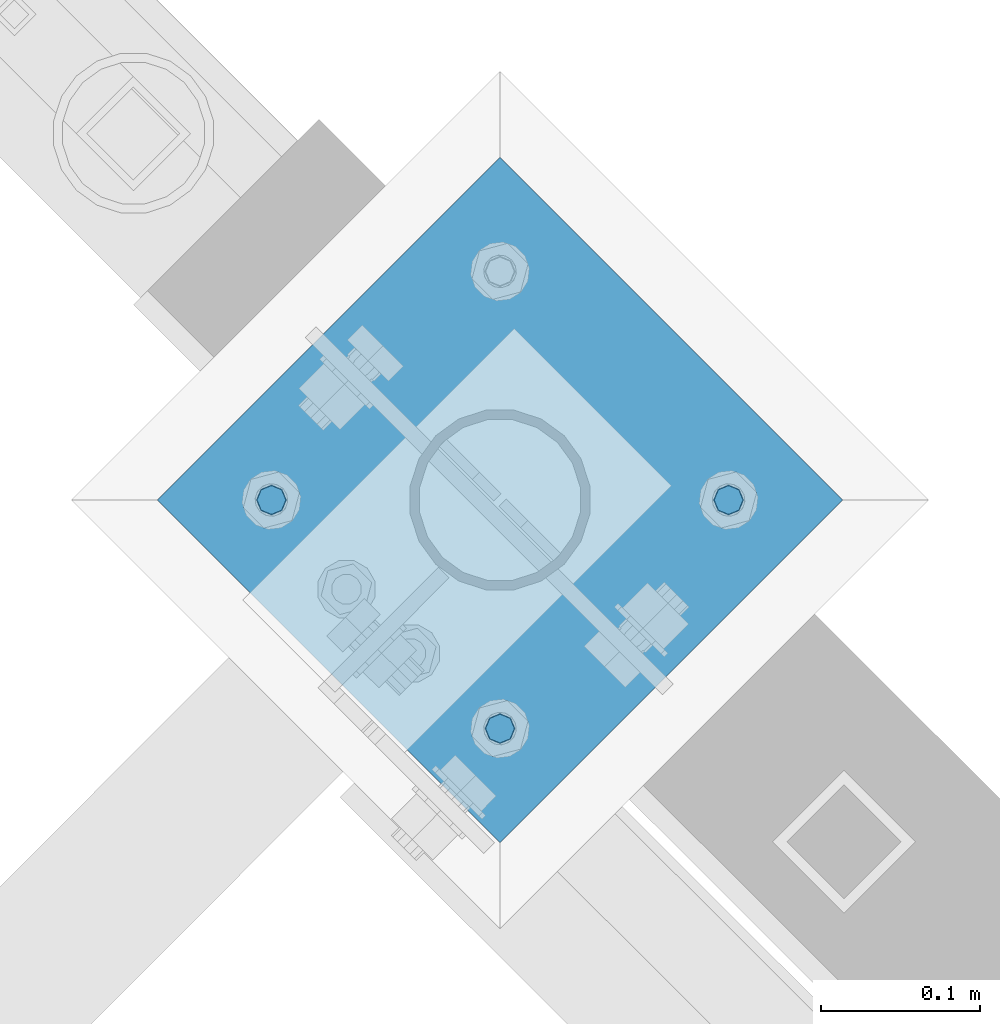
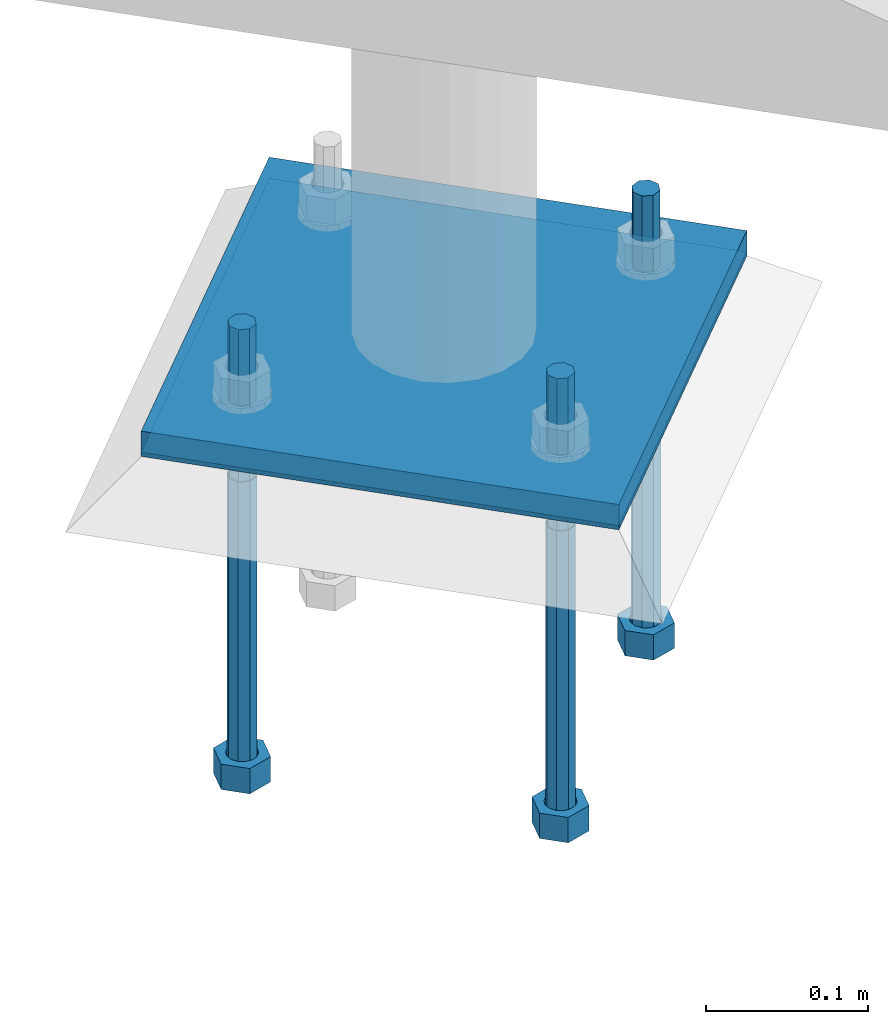
# One storey, part 448 of 975: 5 beams.
"""IFC2X3 building model written with IfcOpenShell, lengths in millimetres."""

from ifc_helpers import new_model, si_unit, frame, origin_with_axes, place, context, subcontext, project, spatial, faceted_brep, material, type_object, element, save


model = new_model("IFC2X3")

# Units and contexts
model_context = context("Model", 3, precision=1e-05, world=origin_with_axes())
body_context = subcontext(model_context, "Body", "Model", "MODEL_VIEW")
ifc_project = project(units=[si_unit("LENGTHUNIT", "METRE", prefix="MILLI"), si_unit("AREAUNIT", "SQUARE_METRE"), si_unit("VOLUMEUNIT", "CUBIC_METRE"), si_unit("MASSUNIT", "GRAM", prefix="KILO"), si_unit("TIMEUNIT", "SECOND"), si_unit("PLANEANGLEUNIT", "RADIAN"), si_unit("SOLIDANGLEUNIT", "STERADIAN"), si_unit("THERMODYNAMICTEMPERATUREUNIT", "DEGREE_CELSIUS"), si_unit("LUMINOUSINTENSITYUNIT", "LUMEN")], contexts=[model_context])

# Site, building, storey
site_placement = place(None, origin_with_axes())
site = spatial("IfcSite", under=ifc_project, at=site_placement, CompositionType="ELEMENT")
building_placement = place(site_placement, origin_with_axes())
building = spatial("IfcBuilding", under=site, at=building_placement, Name="Undefined", CompositionType="ELEMENT")
storey_placement = place(building_placement, origin_with_axes())
storey = spatial("IfcBuildingStorey", under=building, at=storey_placement, Name="Undefined", CompositionType="ELEMENT", Elevation=0.0)

# Beams
ifc_material_1 = material(Name="STEEL/A36")
beam_type_1 = type_object("IfcBeamType", PredefinedType="NOTDEFINED")
beam_1_placement = place(storey_placement, frame((26447.9369265474, 21971.1869265474, -257.175000000002), z_axis=(-0.707106781186601, 0.707106781186494, 2.36468622460961e-14), x_axis=(0.707106781186548, 0.707106781186548, 0.0)))
element("IfcBeam", 1, at=beam_1_placement, inside=storey, type_object=beam_type_1, material=ifc_material_1, Name="PLATE", context=body_context, shape_type="Brep", body=[
    faceted_brep([(0.0, 9.52499999999964, -152.4), (0.0, 9.52499999999964, 152.4), (304.799999999152, 9.52499999999964, 152.4), (304.799999999152, 9.52499999999964, -152.4), (0.0, -9.52499999999964, 152.4), (304.799999999152, -9.52499999999964, 152.4), (0.0, -9.52499999999964, -152.4), (304.799999999152, -9.52499999999964, -152.4)], [[[0, 1, 2, 3]], [[1, 4, 5, 2]], [[4, 6, 7, 5]], [[6, 0, 3, 7]], [[5, 7, 3, 2]], [[6, 4, 1, 0]]]),
])
ifc_material_2 = material(Name="STEEL/F1554-36")
beam_type_2 = type_object("IfcBeamType", PredefinedType="NOTDEFINED")
beam_2_placement = place(storey_placement, frame((26555.700001079, 21935.2659053001, -304.799999999999), z_axis=(0.707106781186548, 0.707106781186548, 0.0), x_axis=(0.0, 0.0, -1.0)))
element("IfcBeam", 2, at=beam_2_placement, inside=storey, type_object=beam_type_2, material=ifc_material_2, Name="HEADED_ANCHOR_BOLT", context=body_context, shape_type="Brep", body=[
    faceted_brep([(209.543749999999, -9.13000011446275, 15.8100004196049), (209.543749999999, -18.2600002288382, 4.72937244921923e-11), (228.593749999998, -18.2600002288382, 4.72937244921923e-11), (228.593749999998, -9.13000011446275, 15.8100004196049), (209.543749999999, 9.13000011438271, 15.8100004195576), (228.593749999998, 9.13000011438271, 15.8100004195576), (209.543749999999, 18.2600002288382, -4.72937244921923e-11), (228.593749999998, 18.2600002288382, -4.72937244921923e-11), (209.543749999999, 9.13000011446275, -15.8100004196049), (228.593749999998, 9.13000011446275, -15.8100004196049), (209.543749999999, -9.13000011438271, -15.8100004195576), (228.593749999998, -9.13000011438271, -15.8100004195576), (209.543749999999, -4.4776800552936, 9.29799844178979), (209.543749999999, -8.068500660469, 6.43441456491473), (209.543749999999, -10.0612557561763, 2.2964159705416), (209.543749999999, -10.0612557561617, -2.29641597048976), (209.543749999999, -8.0685006604399, -6.4344145648729), (209.543749999999, -4.47768005524995, -9.29799844176705), (209.543749999999, 2.91038304567337e-11, -10.3199996948015), (209.543749999999, 4.4776800552936, -9.29799844178979), (209.543749999999, 8.068500660469, -6.43441456491473), (209.543749999999, 10.0612557561763, -2.2964159705416), (209.543749999999, 10.0612557561617, 2.29641597048976), (209.543749999999, 8.0685006604399, 6.4344145648729), (209.543749999999, 4.47768005524995, 9.29799844176705), (209.543749999999, -2.91038304567337e-11, 10.3199996948015), (228.593749999998, -2.91038304567337e-11, 10.3199996948015), (228.593749999998, -4.4776800552936, 9.29799844178979), (228.593749999998, -8.068500660469, 6.43441456491473), (228.593749999998, -10.0612557561763, 2.2964159705416), (228.593749999998, -10.0612557561617, -2.29641597048976), (228.593749999998, -8.0685006604399, -6.4344145648729), (228.593749999998, -4.47768005524995, -9.29799844176705), (228.593749999998, 2.91038304567337e-11, -10.3199996948015), (228.593749999998, 4.4776800552936, -9.29799844178979), (228.593749999998, 8.068500660469, -6.43441456491473), (228.593749999998, 10.0612557561763, -2.2964159705416), (228.593749999998, 10.0612557561617, 2.29641597048976), (228.593749999998, 8.0685006604399, 6.4344145648729), (228.593749999998, 4.47768005524995, 9.29799844176705), (0.0, -6.73519209080223, 6.73519209080186), (0.0, -9.52499999999964, 0.0), (228.6, -9.52500000000146, 0.0), (228.6, -6.73519209080405, 6.73519209080223), (-9.87109982941227e-13, -1.20792265079217e-13, 9.52499961853027), (228.6, 0.0, 9.52499999999964), (0.0, 6.73519209080223, 6.73519209080186), (228.6, 6.73519209080405, 6.73519209080223), (0.0, 9.52499999999964, 0.0), (228.6, 9.52500000000146, 0.0), (0.0, 6.73519209080223, -6.73519209080186), (228.6, 6.73519209080405, -6.73519209080223), (2.95075507493764e-12, -1.20792265079217e-13, -9.52499961853027), (228.6, 0.0, -9.52499999999964), (-114.297914995421, -6.36396103067818, 6.36396103068091), (-114.297914995421, -2.18278728425503e-11, 8.99999999997999), (-114.297914995421, 6.36396103064908, 6.36396103064817), (-114.297914995421, 8.99999999997817, -2.27373675443232e-11), (-114.297914995421, 6.36396103067818, -6.36396103068091), (-114.297914995421, 2.18278728425503e-11, -8.99999999997999), (-114.297914995421, -6.36396103064908, -6.36396103064817), (-114.297914995421, -8.99999999997817, 2.27373675443232e-11), (0.0149743263646087, 6.36396103067818, -6.36396103067909), (0.0149743263646087, 0.0, -9.0), (0.0149743263646087, -6.36396103067818, -6.36396103067909), (0.0149743263987148, -8.9999995411581, -1.00796984270346e-06), (0.0149743263646087, -6.36396103067818, 6.36396103067909), (0.0149743263646087, 0.0, 9.0), (0.0149743263646087, 6.36396103067818, 6.36396103067909), (0.0149743263987148, 9.0000004588419, -1.00796984270346e-06), (0.0, -6.73519209080223, -6.73519209080186), (228.6, -6.73519209080405, -6.73519209080223)], [[[0, 1, 2, 3]], [[4, 0, 3, 5]], [[6, 4, 5, 7]], [[8, 6, 7, 9]], [[10, 8, 9, 11]], [[0, 4, 6, 8, 10, 1], [12, 13, 14, 15, 16, 17, 18, 19, 20, 21, 22, 23, 24, 25]], [[12, 25, 26, 27]], [[13, 12, 27, 28]], [[14, 13, 28, 29]], [[15, 14, 29, 30]], [[16, 15, 30, 31]], [[17, 16, 31, 32]], [[18, 17, 32, 33]], [[19, 18, 33, 34]], [[20, 19, 34, 35]], [[21, 20, 35, 36]], [[22, 21, 36, 37]], [[23, 22, 37, 38]], [[24, 23, 38, 39]], [[25, 24, 39, 26]], [[9, 7, 5, 3, 2, 11], [38, 37, 36, 35, 34, 33, 32, 31, 30, 29, 28, 27, 26, 39]], [[1, 10, 11, 2]], [[40, 41, 42, 43]], [[44, 40, 43, 45]], [[46, 44, 45, 47]], [[48, 46, 47, 49]], [[50, 48, 49, 51]], [[52, 50, 51, 53]], [[54, 55, 56, 57, 58, 59, 60, 61]], [[59, 58, 62, 63]], [[60, 59, 63, 64]], [[61, 60, 64, 65]], [[54, 61, 65, 66]], [[55, 54, 66, 67]], [[56, 55, 67, 68]], [[57, 56, 68, 69]], [[58, 57, 69, 62]], [[40, 44, 46, 48, 50, 52, 70, 41], [68, 67, 66, 65, 64, 63, 62, 69]], [[41, 70, 71, 42]], [[53, 51, 49, 47, 45, 43, 42, 71]], [[70, 52, 53, 71]]]),
])
beam_3_placement = place(storey_placement, frame((26412.0159053001, 22078.950001079, -304.799999999999), z_axis=(0.707106781186548, 0.707106781186548, 0.0), x_axis=(0.0, 0.0, -1.0)))
element("IfcBeam", 3, at=beam_3_placement, inside=storey, type_object=beam_type_2, material=ifc_material_2, Name="HEADED_ANCHOR_BOLT", context=body_context, shape_type="Brep", body=[
    faceted_brep([(209.543749999999, 9.13000011446275, -15.8100004196049), (209.543749999999, 18.2600002288382, -4.72937244921923e-11), (228.593749999998, 18.2600002288382, -4.72937244921923e-11), (228.593749999998, 9.13000011446275, -15.8100004196049), (209.543749999999, -9.13000011438271, -15.8100004195576), (228.593749999998, -9.13000011438271, -15.8100004195576), (209.543749999999, -18.2600002288382, 4.72937244921923e-11), (228.593749999998, -18.2600002288382, 4.72937244921923e-11), (209.543749999999, -9.13000011446275, 15.8100004196049), (228.593749999998, -9.13000011446275, 15.8100004196049), (209.543749999999, 9.13000011438271, 15.8100004195576), (228.593749999998, 9.13000011438271, 15.8100004195576), (209.543749999999, -4.4776800552936, 9.29799844178979), (209.543749999999, -8.068500660469, 6.43441456491473), (209.543749999999, -10.0612557561763, 2.2964159705416), (209.543749999999, -10.0612557561617, -2.29641597048976), (209.543749999999, -8.0685006604399, -6.4344145648729), (209.543749999999, -4.47768005524995, -9.29799844176705), (209.543749999999, 2.91038304567337e-11, -10.3199996948015), (209.543749999999, 4.4776800552936, -9.29799844178979), (209.543749999999, 8.068500660469, -6.43441456491473), (209.543749999999, 10.0612557561763, -2.2964159705416), (209.543749999999, 10.0612557561617, 2.29641597048976), (209.543749999999, 8.0685006604399, 6.4344145648729), (209.543749999999, 4.47768005524995, 9.29799844176705), (209.543749999999, -2.91038304567337e-11, 10.3199996948015), (228.593749999998, 2.91038304567337e-11, -10.3199996948015), (228.593749999998, 4.4776800552936, -9.29799844178979), (228.593749999998, 8.068500660469, -6.43441456491473), (228.593749999998, 10.0612557561763, -2.2964159705416), (228.593749999998, 10.0612557561617, 2.29641597048976), (228.593749999998, 8.0685006604399, 6.4344145648729), (228.593749999998, 4.47768005524995, 9.29799844176705), (228.593749999998, -2.91038304567337e-11, 10.3199996948015), (228.593749999998, -4.4776800552936, 9.29799844178979), (228.593749999998, -8.068500660469, 6.43441456491473), (228.593749999998, -10.0612557561763, 2.2964159705416), (228.593749999998, -10.0612557561617, -2.29641597048976), (228.593749999998, -8.0685006604399, -6.4344145648729), (228.593749999998, -4.47768005524995, -9.29799844176705), (0.0, -6.73519209080223, 6.73519209080186), (0.0, -9.52499999999964, 0.0), (228.6, -9.52500000000146, 0.0), (228.6, -6.73519209080405, 6.73519209080223), (-9.87109982941227e-13, -1.20792265079217e-13, 9.52499961853027), (228.6, 0.0, 9.52499999999964), (0.0, 6.73519209080223, 6.73519209080186), (228.6, 6.73519209080405, 6.73519209080223), (0.0, 9.52499999999964, 0.0), (228.6, 9.52500000000146, 0.0), (0.0, 6.73519209080223, -6.73519209080186), (228.6, 6.73519209080405, -6.73519209080223), (2.95075507493764e-12, -1.20792265079217e-13, -9.52499961853027), (228.6, 0.0, -9.52499999999964), (-114.297914995421, -6.36396103067818, 6.36396103068091), (-114.297914995421, -2.18278728425503e-11, 8.99999999997999), (-114.297914995421, 6.36396103064908, 6.36396103064817), (-114.297914995421, 8.99999999997817, -2.27373675443232e-11), (-114.297914995421, 6.36396103067818, -6.36396103068091), (-114.297914995421, 2.18278728425503e-11, -8.99999999997999), (-114.297914995421, -6.36396103064908, -6.36396103064817), (-114.297914995421, -8.99999999997817, 2.27373675443232e-11), (0.0149743263646087, 6.36396103067818, -6.36396103067909), (0.0149743263646087, 0.0, -9.0), (0.0149743263646087, -6.36396103067818, -6.36396103067909), (0.0149743263987148, -8.9999995411581, -1.00796984270346e-06), (0.0149743263646087, -6.36396103067818, 6.36396103067909), (0.0149743263646087, 0.0, 9.0), (0.0149743263646087, 6.36396103067818, 6.36396103067909), (0.0149743263987148, 9.0000004588419, -1.00796984270346e-06), (0.0, -6.73519209080223, -6.73519209080186), (228.6, -6.73519209080405, -6.73519209080223)], [[[0, 1, 2, 3]], [[4, 0, 3, 5]], [[6, 4, 5, 7]], [[8, 6, 7, 9]], [[10, 8, 9, 11]], [[8, 10, 1, 0, 4, 6], [12, 13, 14, 15, 16, 17, 18, 19, 20, 21, 22, 23, 24, 25]], [[19, 18, 26, 27]], [[20, 19, 27, 28]], [[21, 20, 28, 29]], [[22, 21, 29, 30]], [[23, 22, 30, 31]], [[24, 23, 31, 32]], [[25, 24, 32, 33]], [[12, 25, 33, 34]], [[13, 12, 34, 35]], [[14, 13, 35, 36]], [[15, 14, 36, 37]], [[16, 15, 37, 38]], [[17, 16, 38, 39]], [[18, 17, 39, 26]], [[3, 2, 11, 9, 7, 5], [31, 30, 29, 28, 27, 26, 39, 38, 37, 36, 35, 34, 33, 32]], [[1, 10, 11, 2]], [[40, 41, 42, 43]], [[44, 40, 43, 45]], [[46, 44, 45, 47]], [[48, 46, 47, 49]], [[50, 48, 49, 51]], [[52, 50, 51, 53]], [[54, 55, 56, 57, 58, 59, 60, 61]], [[59, 58, 62, 63]], [[60, 59, 63, 64]], [[61, 60, 64, 65]], [[54, 61, 65, 66]], [[55, 54, 66, 67]], [[56, 55, 67, 68]], [[57, 56, 68, 69]], [[58, 57, 69, 62]], [[40, 44, 46, 48, 50, 52, 70, 41], [68, 67, 66, 65, 64, 63, 62, 69]], [[41, 70, 71, 42]], [[53, 51, 49, 47, 45, 43, 42, 71]], [[70, 52, 53, 71]]]),
])
beam_4_placement = place(storey_placement, frame((26699.3840968578, 22078.950001079, -304.799999999999), z_axis=(0.707106781186548, 0.707106781186548, 0.0), x_axis=(0.0, 0.0, -1.0)))
element("IfcBeam", 4, at=beam_4_placement, inside=storey, type_object=beam_type_2, material=ifc_material_2, Name="HEADED_ANCHOR_BOLT", context=body_context, shape_type="Brep", body=[
    faceted_brep([(209.543749999999, -9.13000011446275, 15.8100004196049), (209.543749999999, -18.2600002288382, 4.72937244921923e-11), (228.593749999998, -18.2600002288382, 4.72937244921923e-11), (228.593749999998, -9.13000011446275, 15.8100004196049), (209.543749999999, 9.13000011438271, 15.8100004195576), (228.593749999998, 9.13000011438271, 15.8100004195576), (209.543749999999, 18.2600002288382, -4.72937244921923e-11), (228.593749999998, 18.2600002288382, -4.72937244921923e-11), (209.543749999999, 9.13000011446275, -15.8100004196049), (228.593749999998, 9.13000011446275, -15.8100004196049), (209.543749999999, -9.13000011438271, -15.8100004195576), (228.593749999998, -9.13000011438271, -15.8100004195576), (209.543749999999, -4.4776800552936, 9.29799844178979), (209.543749999999, -8.068500660469, 6.43441456491473), (209.543749999999, -10.0612557561763, 2.2964159705416), (209.543749999999, -10.0612557561617, -2.29641597048976), (209.543749999999, -8.0685006604399, -6.4344145648729), (209.543749999999, -4.47768005524995, -9.29799844176705), (209.543749999999, 2.91038304567337e-11, -10.3199996948015), (209.543749999999, 4.4776800552936, -9.29799844178979), (209.543749999999, 8.068500660469, -6.43441456491473), (209.543749999999, 10.0612557561763, -2.2964159705416), (209.543749999999, 10.0612557561617, 2.29641597048976), (209.543749999999, 8.0685006604399, 6.4344145648729), (209.543749999999, 4.47768005524995, 9.29799844176705), (209.543749999999, -2.91038304567337e-11, 10.3199996948015), (228.593749999998, -2.91038304567337e-11, 10.3199996948015), (228.593749999998, -4.4776800552936, 9.29799844178979), (228.593749999998, -8.068500660469, 6.43441456491473), (228.593749999998, -10.0612557561763, 2.2964159705416), (228.593749999998, -10.0612557561617, -2.29641597048976), (228.593749999998, -8.0685006604399, -6.4344145648729), (228.593749999998, -4.47768005524995, -9.29799844176705), (228.593749999998, 2.91038304567337e-11, -10.3199996948015), (228.593749999998, 4.4776800552936, -9.29799844178979), (228.593749999998, 8.068500660469, -6.43441456491473), (228.593749999998, 10.0612557561763, -2.2964159705416), (228.593749999998, 10.0612557561617, 2.29641597048976), (228.593749999998, 8.0685006604399, 6.4344145648729), (228.593749999998, 4.47768005524995, 9.29799844176705), (0.0, -6.73519209080223, 6.73519209080186), (0.0, -9.52499999999964, 0.0), (228.6, -9.52500000000146, 0.0), (228.6, -6.73519209080405, 6.73519209080223), (-9.87109982941227e-13, -1.20792265079217e-13, 9.52499961853027), (228.6, 0.0, 9.52499999999964), (0.0, 6.73519209080223, 6.73519209080186), (228.6, 6.73519209080405, 6.73519209080223), (0.0, 9.52499999999964, 0.0), (228.6, 9.52500000000146, 0.0), (0.0, 6.73519209080223, -6.73519209080186), (228.6, 6.73519209080405, -6.73519209080223), (2.95075507493764e-12, -1.20792265079217e-13, -9.52499961853027), (228.6, 0.0, -9.52499999999964), (-114.297914995421, -6.36396103067818, 6.36396103068091), (-114.297914995421, -2.18278728425503e-11, 8.99999999997999), (-114.297914995421, 6.36396103064908, 6.36396103064817), (-114.297914995421, 8.99999999997817, -2.27373675443232e-11), (-114.297914995421, 6.36396103067818, -6.36396103068091), (-114.297914995421, 2.18278728425503e-11, -8.99999999997999), (-114.297914995421, -6.36396103064908, -6.36396103064817), (-114.297914995421, -8.99999999997817, 2.27373675443232e-11), (0.0149743263646087, 6.36396103067818, -6.36396103067909), (0.0149743263646087, 0.0, -9.0), (0.0149743263646087, -6.36396103067818, -6.36396103067909), (0.0149743263987148, -8.9999995411581, -1.00796984270346e-06), (0.0149743263646087, -6.36396103067818, 6.36396103067909), (0.0149743263646087, 0.0, 9.0), (0.0149743263646087, 6.36396103067818, 6.36396103067909), (0.0149743263987148, 9.0000004588419, -1.00796984270346e-06), (0.0, -6.73519209080223, -6.73519209080186), (228.6, -6.73519209080405, -6.73519209080223)], [[[0, 1, 2, 3]], [[4, 0, 3, 5]], [[6, 4, 5, 7]], [[8, 6, 7, 9]], [[10, 8, 9, 11]], [[0, 4, 6, 8, 10, 1], [12, 13, 14, 15, 16, 17, 18, 19, 20, 21, 22, 23, 24, 25]], [[12, 25, 26, 27]], [[13, 12, 27, 28]], [[14, 13, 28, 29]], [[15, 14, 29, 30]], [[16, 15, 30, 31]], [[17, 16, 31, 32]], [[18, 17, 32, 33]], [[19, 18, 33, 34]], [[20, 19, 34, 35]], [[21, 20, 35, 36]], [[22, 21, 36, 37]], [[23, 22, 37, 38]], [[24, 23, 38, 39]], [[25, 24, 39, 26]], [[9, 7, 5, 3, 2, 11], [38, 37, 36, 35, 34, 33, 32, 31, 30, 29, 28, 27, 26, 39]], [[1, 10, 11, 2]], [[40, 41, 42, 43]], [[44, 40, 43, 45]], [[46, 44, 45, 47]], [[48, 46, 47, 49]], [[50, 48, 49, 51]], [[52, 50, 51, 53]], [[54, 55, 56, 57, 58, 59, 60, 61]], [[59, 58, 62, 63]], [[60, 59, 63, 64]], [[61, 60, 64, 65]], [[54, 61, 65, 66]], [[55, 54, 66, 67]], [[56, 55, 67, 68]], [[57, 56, 68, 69]], [[58, 57, 69, 62]], [[40, 44, 46, 48, 50, 52, 70, 41], [68, 67, 66, 65, 64, 63, 62, 69]], [[41, 70, 71, 42]], [[53, 51, 49, 47, 45, 43, 42, 71]], [[70, 52, 53, 71]]]),
])
beam_type_3 = type_object("IfcBeamType", PredefinedType="NOTDEFINED")
beam_5_placement = place(storey_placement, frame((26447.9369265474, 21971.1869265474, -265.112500000001), z_axis=(-0.707106781186601, 0.707106781186494, 2.36468622460961e-14), x_axis=(0.707106781186548, 0.707106781186548, 0.0)))
element("IfcBeam", 5, at=beam_5_placement, inside=storey, type_object=beam_type_3, material=ifc_material_1, Name="TEMPLATE", context=body_context, shape_type="Brep", body=[
    faceted_brep([(0.0, 1.58750000000009, -152.4), (0.0, 1.58750000000009, 152.4), (304.799999999153, 1.58750000000001, 152.400000000001), (304.799999999153, 1.58750000000001, -152.400000000001), (0.0, -1.58750000000009, 152.4), (304.799999999153, -1.58750000000001, 152.400000000001), (0.0, -1.58750000000009, -152.4), (304.799999999153, -1.58750000000001, -152.400000000001)], [[[0, 1, 2, 3]], [[1, 4, 5, 2]], [[4, 6, 7, 5]], [[6, 0, 3, 7]], [[5, 7, 3, 2]], [[6, 4, 1, 0]]]),
])

save(model, "model.ifc")
